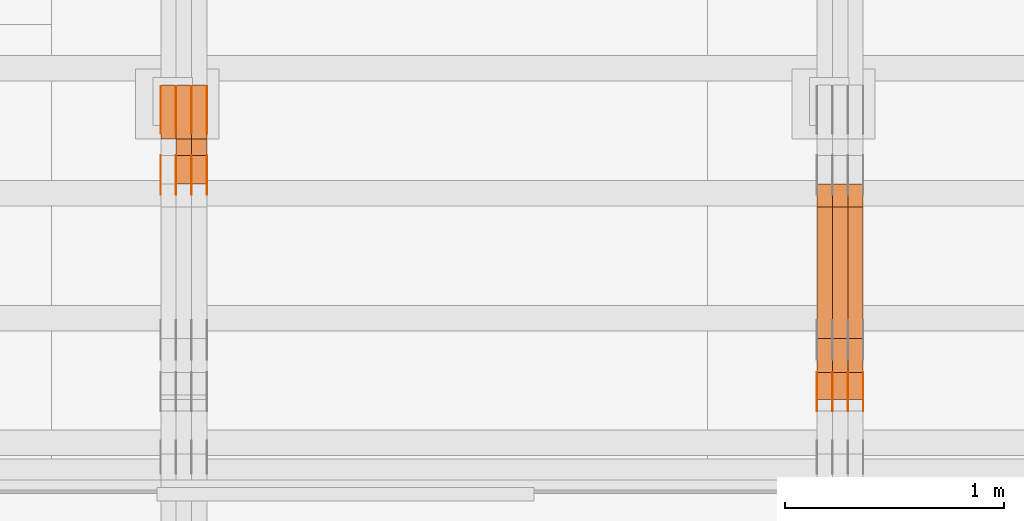
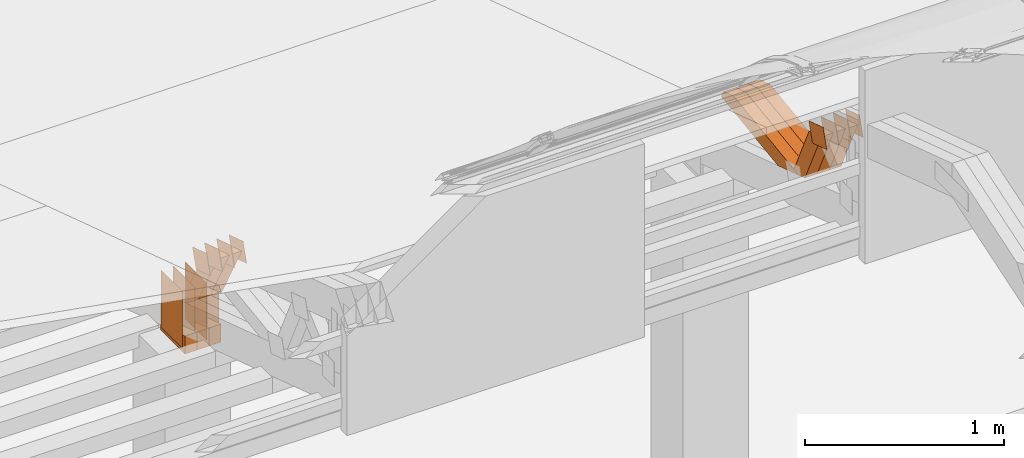
# One storey, part 163 of 385: 29 proxies.
"""IFC2X3 building model written with IfcOpenShell, lengths in millimetres."""

from ifc_helpers import new_model, entity, si_unit, converted_unit, derived_unit, direction, frame, origin, origin_2d_with_axis, place, context, subcontext, project, spatial, polyline, rectangle, outline, extrude, source, transform, mapped, material, type_object, type_shapes, element, save


model = new_model("IFC2X3")

# Units and contexts
model_context = context("Model", 3, precision=0.01, world=origin(), true_north=direction((6.12303176911189e-17, 1.0)))
body_context = subcontext(model_context, "Body", "Model", "MODEL_VIEW")
ifc_project = project(units=[si_unit("LENGTHUNIT", "METRE", prefix="MILLI"), si_unit("AREAUNIT", "SQUARE_METRE"), si_unit("VOLUMEUNIT", "CUBIC_METRE"), converted_unit("PLANEANGLEUNIT", "DEGREE", entity("IfcRatioMeasure", 0.0174532925199433), si_unit("PLANEANGLEUNIT", "RADIAN"), dimensions=[0, 0, 0, 0, 0, 0, 0]), si_unit("MASSUNIT", "GRAM", prefix="KILO"), derived_unit("MASSDENSITYUNIT", [(si_unit("MASSUNIT", "GRAM", prefix="KILO"), 1), (si_unit("LENGTHUNIT", "METRE"), -3)]), si_unit("TIMEUNIT", "SECOND"), si_unit("FREQUENCYUNIT", "HERTZ"), si_unit("THERMODYNAMICTEMPERATUREUNIT", "DEGREE_CELSIUS"), derived_unit("THERMALTRANSMITTANCEUNIT", [(si_unit("MASSUNIT", "GRAM", prefix="KILO"), 1), (si_unit("THERMODYNAMICTEMPERATUREUNIT", "KELVIN"), -1), (si_unit("TIMEUNIT", "SECOND"), -3)]), derived_unit("VOLUMETRICFLOWRATEUNIT", [(si_unit("LENGTHUNIT", "METRE"), 3), (si_unit("TIMEUNIT", "SECOND"), -1)]), si_unit("ELECTRICCURRENTUNIT", "AMPERE"), si_unit("ELECTRICVOLTAGEUNIT", "VOLT"), si_unit("POWERUNIT", "WATT"), si_unit("FORCEUNIT", "NEWTON", prefix="KILO"), si_unit("ILLUMINANCEUNIT", "LUX"), si_unit("LUMINOUSFLUXUNIT", "LUMEN"), si_unit("LUMINOUSINTENSITYUNIT", "CANDELA"), derived_unit("USERDEFINED", [(si_unit("MASSUNIT", "GRAM", prefix="KILO"), -1), (si_unit("LENGTHUNIT", "METRE"), -2), (si_unit("TIMEUNIT", "SECOND"), 3), (si_unit("LUMINOUSFLUXUNIT", "LUMEN"), 1)]), derived_unit("LINEARVELOCITYUNIT", [(si_unit("LENGTHUNIT", "METRE"), 1), (si_unit("TIMEUNIT", "SECOND"), -1)]), si_unit("PRESSUREUNIT", "PASCAL"), derived_unit("USERDEFINED", [(si_unit("LENGTHUNIT", "METRE"), -2), (si_unit("MASSUNIT", "GRAM", prefix="KILO"), 1), (si_unit("TIMEUNIT", "SECOND"), -2)])], contexts=[model_context])

# Site, building, storey
site_placement = place(None, origin())
site = spatial("IfcSite", under=ifc_project, at=site_placement, CompositionType="ELEMENT")
building_placement = place(site_placement, origin())
building = spatial("IfcBuilding", under=site, at=building_placement, CompositionType="ELEMENT")
storey_placement = place(building_placement, origin())
storey = spatial("IfcBuildingStorey", under=building, at=storey_placement, Name="Default", CompositionType="ELEMENT", Elevation=0.0)

# Proxies
ifc_material_1 = material(Name="IfcSurfaceStyle #338318")
building_element_proxy_type_1 = type_object("IfcBuildingElementProxyType", PredefinedType="NOTDEFINED", material=ifc_material_1)
shared_shape_1 = source(origin(), body_context, "Body", "SweptSolid", [
    extrude(outline(polyline([(-75.0003249421702, -60.0000773549573), (75.0003398116874, -60.0000773549573), (75.0003249421711, 60.0000773549573), (-75.0003398116883, 60.0000773549573), (-75.0003249421702, -60.0000773549573)])), frame((75.0003398116874, 60.0000773549573, 0.0), z_axis=(0.0, 0.0, 1.0), x_axis=(-1.0, 0.0, 0.0)), (0.0, 0.0, 1.0), 1.3),
])
type_shapes(building_element_proxy_type_1, [shared_shape_1])
proxy_1_placement = place(building_placement, frame((27386.3, 16117.0849050545, 3705.49074668796), z_axis=(-1.0, 0.0, 0.0), x_axis=(0.0, -0.951056516295154, 0.309016994374948)))
element("IfcBuildingElementProxy", 1, at=proxy_1_placement, inside=storey, type_object=building_element_proxy_type_1, material=ifc_material_1, context=body_context, shape_type="MappedRepresentation", body=[
    mapped(shared_shape_1, transform((0.0, 0.0, 0.0), scale=1.0)),
])
ifc_material_2 = material(Name="IfcSurfaceStyle #338261")
building_element_proxy_type_2 = type_object("IfcBuildingElementProxyType", PredefinedType="NOTDEFINED", material=ifc_material_2)
shared_shape_2 = source(origin(), body_context, "Body", "SweptSolid", [
    extrude(outline(polyline([(-75.0003249421702, -60.0000773549573), (75.0003398116874, -60.0000773549573), (75.0003249421711, 60.0000773549573), (-75.0003398116883, 60.0000773549573), (-75.0003249421702, -60.0000773549573)])), frame((75.0003398116874, 60.0000773549573, 0.0), z_axis=(0.0, 0.0, 1.0), x_axis=(-1.0, 0.0, 0.0)), (0.0, 0.0, 1.0), 1.3),
])
type_shapes(building_element_proxy_type_2, [shared_shape_2])
proxy_2_placement = place(building_placement, frame((27315.0, 16117.0849050545, 3705.49074668796), z_axis=(-1.0, 0.0, 0.0), x_axis=(0.0, -0.951056516295154, 0.309016994374948)))
element("IfcBuildingElementProxy", 2, at=proxy_2_placement, inside=storey, type_object=building_element_proxy_type_2, material=ifc_material_2, context=body_context, shape_type="MappedRepresentation", body=[
    mapped(shared_shape_2, transform((0.0, 0.0, 0.0), scale=1.0)),
])
ifc_material_3 = material(Name="IfcSurfaceStyle #338204")
building_element_proxy_type_3 = type_object("IfcBuildingElementProxyType", PredefinedType="NOTDEFINED", material=ifc_material_3)
shared_shape_3 = source(origin(), body_context, "Body", "SweptSolid", [
    extrude(outline(polyline([(-75.0003249421702, -60.0000773549573), (75.0003398116874, -60.0000773549573), (75.0003249421711, 60.0000773549573), (-75.0003398116883, 60.0000773549573), (-75.0003249421702, -60.0000773549573)])), frame((75.0003398116874, 60.0000773549573, 0.0), z_axis=(0.0, 0.0, 1.0), x_axis=(-1.0, 0.0, 0.0)), (0.0, 0.0, 1.0), 1.3),
])
type_shapes(building_element_proxy_type_3, [shared_shape_3])
proxy_3_placement = place(building_placement, frame((27316.3, 16117.0849050545, 3705.49074668796), z_axis=(-1.0, 0.0, 0.0), x_axis=(0.0, -0.951056516295154, 0.309016994374948)))
element("IfcBuildingElementProxy", 3, at=proxy_3_placement, inside=storey, type_object=building_element_proxy_type_3, material=ifc_material_3, context=body_context, shape_type="MappedRepresentation", body=[
    mapped(shared_shape_3, transform((0.0, 0.0, 0.0), scale=1.0)),
])
ifc_material_4 = material(Name="IfcSurfaceStyle #338147")
building_element_proxy_type_4 = type_object("IfcBuildingElementProxyType", PredefinedType="NOTDEFINED", material=ifc_material_4)
shared_shape_4 = source(origin(), body_context, "Body", "SweptSolid", [
    extrude(outline(polyline([(-75.0003249421702, -60.0000773549573), (75.0003398116874, -60.0000773549573), (75.0003249421711, 60.0000773549573), (-75.0003398116883, 60.0000773549573), (-75.0003249421702, -60.0000773549573)])), frame((75.0003398116874, 60.0000773549573, 0.0), z_axis=(0.0, 0.0, 1.0), x_axis=(-1.0, 0.0, 0.0)), (0.0, 0.0, 1.0), 1.29999999999999),
])
type_shapes(building_element_proxy_type_4, [shared_shape_4])
proxy_4_placement = place(building_placement, frame((27245.0, 16117.0849050545, 3705.49074668796), z_axis=(-1.0, 0.0, 0.0), x_axis=(0.0, -0.951056516295154, 0.309016994374948)))
element("IfcBuildingElementProxy", 4, at=proxy_4_placement, inside=storey, type_object=building_element_proxy_type_4, material=ifc_material_4, context=body_context, shape_type="MappedRepresentation", body=[
    mapped(shared_shape_4, transform((0.0, 0.0, 0.0), scale=1.0)),
])
ifc_material_5 = material(Name="IfcSurfaceStyle #338090")
building_element_proxy_type_5 = type_object("IfcBuildingElementProxyType", PredefinedType="NOTDEFINED", material=ifc_material_5)
shared_shape_5 = source(origin(), body_context, "Body", "SweptSolid", [
    extrude(outline(polyline([(-75.0003249421702, -60.0000773549573), (75.0003398116874, -60.0000773549573), (75.0003249421711, 60.0000773549573), (-75.0003398116883, 60.0000773549573), (-75.0003249421702, -60.0000773549573)])), frame((75.0003398116874, 60.0000773549573, 0.0), z_axis=(0.0, 0.0, 1.0), x_axis=(-1.0, 0.0, 0.0)), (0.0, 0.0, 1.0), 1.29999999999999),
])
type_shapes(building_element_proxy_type_5, [shared_shape_5])
proxy_5_placement = place(building_placement, frame((27246.3, 16117.0849050545, 3705.49074668796), z_axis=(-1.0, 0.0, 0.0), x_axis=(0.0, -0.951056516295154, 0.309016994374948)))
element("IfcBuildingElementProxy", 5, at=proxy_5_placement, inside=storey, type_object=building_element_proxy_type_5, material=ifc_material_5, context=body_context, shape_type="MappedRepresentation", body=[
    mapped(shared_shape_5, transform((0.0, 0.0, 0.0), scale=1.0)),
])
ifc_material_6 = material(Name="IfcSurfaceStyle #338033")
building_element_proxy_type_6 = type_object("IfcBuildingElementProxyType", PredefinedType="NOTDEFINED", material=ifc_material_6)
shared_shape_6 = source(origin(), body_context, "Body", "SweptSolid", [
    extrude(outline(polyline([(-75.0003249421702, -60.0000773549573), (75.0003398116874, -60.0000773549573), (75.0003249421711, 60.0000773549573), (-75.0003398116883, 60.0000773549573), (-75.0003249421702, -60.0000773549573)])), frame((75.0003398116874, 60.0000773549573, 0.0), z_axis=(0.0, 0.0, 1.0), x_axis=(-1.0, 0.0, 0.0)), (0.0, 0.0, 1.0), 1.29999999999999),
])
type_shapes(building_element_proxy_type_6, [shared_shape_6])
proxy_6_placement = place(building_placement, frame((27175.0, 16117.0849050545, 3705.49074668796), z_axis=(-1.0, 0.0, 0.0), x_axis=(0.0, -0.951056516295154, 0.309016994374948)))
element("IfcBuildingElementProxy", 6, at=proxy_6_placement, inside=storey, type_object=building_element_proxy_type_6, material=ifc_material_6, context=body_context, shape_type="MappedRepresentation", body=[
    mapped(shared_shape_6, transform((0.0, 0.0, 0.0), scale=1.0)),
])
ifc_material_7 = material(Name="IfcSurfaceStyle #327698")
building_element_proxy_type_7 = type_object("IfcBuildingElementProxyType", Name="T1-W44 327696", PredefinedType="NOTDEFINED", material=ifc_material_7)
shared_shape_7 = source(origin(), body_context, "Body", "SweptSolid", [
    extrude(outline(polyline([(-184.551057772692, -47.4997984945814), (177.527112951531, -47.4997984945814), (162.630077773546, -0.000452497529500495), (118.068221667048, 47.5000247433462), (-273.674354619433, 47.5000247433462), (-184.551057772692, -47.4997984945814)])), frame((177.527112951531, 47.5002721629815, 0.0), z_axis=(0.0, 0.0, 1.0), x_axis=(-1.0, 0.0, 0.0)), (0.0, 0.0, 1.0), 70.0),
])
type_shapes(building_element_proxy_type_7, [shared_shape_7])
proxy_7_placement = place(building_placement, frame((27385.0, 16220.4899216004, 3388.98238154171), z_axis=(-1.0, 0.0, 0.0), x_axis=(0.0, -0.425335045192995, 0.905035965766374)))
element("IfcBuildingElementProxy", 7, at=proxy_7_placement, inside=storey, type_object=building_element_proxy_type_7, material=ifc_material_7, Name="T1-W44", context=body_context, shape_type="MappedRepresentation", body=[
    mapped(shared_shape_7, transform((0.0, 0.0, 0.0), scale=1.0)),
])
ifc_material_8 = material(Name="IfcSurfaceStyle #327632")
building_element_proxy_type_8 = type_object("IfcBuildingElementProxyType", Name="T1-W44 327630", PredefinedType="NOTDEFINED", material=ifc_material_8)
shared_shape_8 = source(origin(), body_context, "Body", "SweptSolid", [
    extrude(outline(polyline([(-184.551057772692, -47.4997984945814), (177.527112951531, -47.4997984945814), (162.630077773546, -0.000452497529500495), (118.068221667048, 47.5000247433462), (-273.674354619433, 47.5000247433462), (-184.551057772692, -47.4997984945814)])), frame((177.527112951531, 47.5002721629815, 0.0), z_axis=(0.0, 0.0, 1.0), x_axis=(-1.0, 0.0, 0.0)), (0.0, 0.0, 1.0), 70.0),
])
type_shapes(building_element_proxy_type_8, [shared_shape_8])
proxy_8_placement = place(building_placement, frame((27315.0, 16220.4899216004, 3388.98238154171), z_axis=(-1.0, 0.0, 0.0), x_axis=(0.0, -0.425335045192995, 0.905035965766374)))
element("IfcBuildingElementProxy", 8, at=proxy_8_placement, inside=storey, type_object=building_element_proxy_type_8, material=ifc_material_8, Name="T1-W44", context=body_context, shape_type="MappedRepresentation", body=[
    mapped(shared_shape_8, transform((0.0, 0.0, 0.0), scale=1.0)),
])
ifc_material_9 = material(Name="IfcSurfaceStyle #327566")
building_element_proxy_type_9 = type_object("IfcBuildingElementProxyType", Name="T1-W44 327564", PredefinedType="NOTDEFINED", material=ifc_material_9)
shared_shape_9 = source(origin(), body_context, "Body", "SweptSolid", [
    extrude(outline(polyline([(-184.551057772692, -47.4997984945814), (177.527112951531, -47.4997984945814), (162.630077773546, -0.000452497529500495), (118.068221667048, 47.5000247433462), (-273.674354619433, 47.5000247433462), (-184.551057772692, -47.4997984945814)])), frame((177.527112951531, 47.5002721629815, 0.0), z_axis=(0.0, 0.0, 1.0), x_axis=(-1.0, 0.0, 0.0)), (0.0, 0.0, 1.0), 70.0),
])
type_shapes(building_element_proxy_type_9, [shared_shape_9])
proxy_9_placement = place(building_placement, frame((27245.0, 16220.4899216004, 3388.98238154171), z_axis=(-1.0, 0.0, 0.0), x_axis=(0.0, -0.425335045192995, 0.905035965766374)))
element("IfcBuildingElementProxy", 9, at=proxy_9_placement, inside=storey, type_object=building_element_proxy_type_9, material=ifc_material_9, Name="T1-W44", context=body_context, shape_type="MappedRepresentation", body=[
    mapped(shared_shape_9, transform((0.0, 0.0, 0.0), scale=1.0)),
])
ifc_material_10 = material(Name="IfcSurfaceStyle #327302")
building_element_proxy_type_10 = type_object("IfcBuildingElementProxyType", Name="T1-W8 327300", PredefinedType="NOTDEFINED", material=ifc_material_10)
shared_shape_10 = source(origin(), body_context, "Body", "SweptSolid", [
    extrude(outline(polyline([(-476.725263324644, -47.5001051695965), (180.672765845439, -47.5001051695965), (279.11020091716, -1.03605560390907e-06), (296.793624402619, 47.5001056876243), (-279.851327840575, 47.5001056876243), (-476.725263324644, -47.5001051695965)])), frame((296.793624402619, 47.5001056876243, 0.0), z_axis=(0.0, 0.0, 1.0), x_axis=(-1.0, 0.0, 0.0)), (0.0, 0.0, 1.0), 70.0),
])
type_shapes(building_element_proxy_type_10, [shared_shape_10])
proxy_10_placement = place(building_placement, frame((27385.0, 17036.40625, 3432.97192382813), z_axis=(-1.0, 0.0, 0.0), x_axis=(0.0, -0.990844046556832, -0.135011389900564)))
element("IfcBuildingElementProxy", 10, at=proxy_10_placement, inside=storey, type_object=building_element_proxy_type_10, material=ifc_material_10, Name="T1-W8", context=body_context, shape_type="MappedRepresentation", body=[
    mapped(shared_shape_10, transform((0.0, 0.0, 0.0), scale=1.0)),
])
ifc_material_11 = material(Name="IfcSurfaceStyle #327236")
building_element_proxy_type_11 = type_object("IfcBuildingElementProxyType", Name="T1-W8 327234", PredefinedType="NOTDEFINED", material=ifc_material_11)
shared_shape_11 = source(origin(), body_context, "Body", "SweptSolid", [
    extrude(outline(polyline([(-476.725263324644, -47.5001051695965), (180.672765845439, -47.5001051695965), (279.11020091716, -1.03605560390907e-06), (296.793624402619, 47.5001056876243), (-279.851327840575, 47.5001056876243), (-476.725263324644, -47.5001051695965)])), frame((296.793624402619, 47.5001056876243, 0.0), z_axis=(0.0, 0.0, 1.0), x_axis=(-1.0, 0.0, 0.0)), (0.0, 0.0, 1.0), 70.0),
])
type_shapes(building_element_proxy_type_11, [shared_shape_11])
proxy_11_placement = place(building_placement, frame((27315.0, 17036.40625, 3432.97192382813), z_axis=(-1.0, 0.0, 0.0), x_axis=(0.0, -0.990844046556832, -0.135011389900564)))
element("IfcBuildingElementProxy", 11, at=proxy_11_placement, inside=storey, type_object=building_element_proxy_type_11, material=ifc_material_11, Name="T1-W8", context=body_context, shape_type="MappedRepresentation", body=[
    mapped(shared_shape_11, transform((0.0, 0.0, 0.0), scale=1.0)),
])
ifc_material_12 = material(Name="IfcSurfaceStyle #327170")
building_element_proxy_type_12 = type_object("IfcBuildingElementProxyType", Name="T1-W8 327168", PredefinedType="NOTDEFINED", material=ifc_material_12)
shared_shape_12 = source(origin(), body_context, "Body", "SweptSolid", [
    extrude(outline(polyline([(-476.725263324644, -47.5001051695965), (180.672765845439, -47.5001051695965), (279.11020091716, -1.03605560390907e-06), (296.793624402619, 47.5001056876243), (-279.851327840575, 47.5001056876243), (-476.725263324644, -47.5001051695965)])), frame((296.793624402619, 47.5001056876243, 0.0), z_axis=(0.0, 0.0, 1.0), x_axis=(-1.0, 0.0, 0.0)), (0.0, 0.0, 1.0), 70.0),
])
type_shapes(building_element_proxy_type_12, [shared_shape_12])
proxy_12_placement = place(building_placement, frame((27245.0, 17036.40625, 3432.97192382813), z_axis=(-1.0, 0.0, 0.0), x_axis=(0.0, -0.990844046556832, -0.135011389900564)))
element("IfcBuildingElementProxy", 12, at=proxy_12_placement, inside=storey, type_object=building_element_proxy_type_12, material=ifc_material_12, Name="T1-W8", context=body_context, shape_type="MappedRepresentation", body=[
    mapped(shared_shape_12, transform((0.0, 0.0, 0.0), scale=1.0)),
])
ifc_material_13 = material(Name="IfcSurfaceStyle #305938")
building_element_proxy_type_13 = type_object("IfcBuildingElementProxyType", PredefinedType="NOTDEFINED", material=ifc_material_13)
shared_shape_13 = source(origin(), body_context, "Body", "SweptSolid", [
    extrude(rectangle(XDim=350.0, YDim=215.999999999984, at=origin_2d_with_axis()), frame((175.0, 108.0, 0.0), z_axis=(0.0, 0.0, 1.0), x_axis=(-1.0, 0.0, 0.0)), (0.0, 0.0, 1.0), 1.29999999999999),
])
type_shapes(building_element_proxy_type_13, [shared_shape_13])
proxy_13_placement = place(building_placement, frame((24386.3, 17459.2939453125, 3165.36425781251), z_axis=(-1.0, 0.0, 0.0), x_axis=(0.0, 0.0, -1.0)))
element("IfcBuildingElementProxy", 13, at=proxy_13_placement, inside=storey, type_object=building_element_proxy_type_13, material=ifc_material_13, context=body_context, shape_type="MappedRepresentation", body=[
    mapped(shared_shape_13, transform((0.0, 0.0, 0.0), scale=1.0)),
])
ifc_material_14 = material(Name="IfcSurfaceStyle #305881")
building_element_proxy_type_14 = type_object("IfcBuildingElementProxyType", PredefinedType="NOTDEFINED", material=ifc_material_14)
shared_shape_14 = source(origin(), body_context, "Body", "SweptSolid", [
    extrude(rectangle(XDim=350.0, YDim=215.999999999984, at=origin_2d_with_axis()), frame((175.0, 108.0, 0.0), z_axis=(0.0, 0.0, 1.0), x_axis=(-1.0, 0.0, 0.0)), (0.0, 0.0, 1.0), 1.29999999999999),
])
type_shapes(building_element_proxy_type_14, [shared_shape_14])
proxy_14_placement = place(building_placement, frame((24315.0, 17459.2939453125, 3165.36425781251), z_axis=(-1.0, 0.0, 0.0), x_axis=(0.0, 0.0, -1.0)))
element("IfcBuildingElementProxy", 14, at=proxy_14_placement, inside=storey, type_object=building_element_proxy_type_14, material=ifc_material_14, context=body_context, shape_type="MappedRepresentation", body=[
    mapped(shared_shape_14, transform((0.0, 0.0, 0.0), scale=1.0)),
])
ifc_material_15 = material(Name="IfcSurfaceStyle #305824")
building_element_proxy_type_15 = type_object("IfcBuildingElementProxyType", PredefinedType="NOTDEFINED", material=ifc_material_15)
shared_shape_15 = source(origin(), body_context, "Body", "SweptSolid", [
    extrude(rectangle(XDim=350.0, YDim=215.999999999984, at=origin_2d_with_axis()), frame((175.0, 108.0, 0.0), z_axis=(0.0, 0.0, 1.0), x_axis=(-1.0, 0.0, 0.0)), (0.0, 0.0, 1.0), 1.29999999999999),
])
type_shapes(building_element_proxy_type_15, [shared_shape_15])
proxy_15_placement = place(building_placement, frame((24316.3, 17459.2939453125, 3165.36425781251), z_axis=(-1.0, 0.0, 0.0), x_axis=(0.0, 0.0, -1.0)))
element("IfcBuildingElementProxy", 15, at=proxy_15_placement, inside=storey, type_object=building_element_proxy_type_15, material=ifc_material_15, context=body_context, shape_type="MappedRepresentation", body=[
    mapped(shared_shape_15, transform((0.0, 0.0, 0.0), scale=1.0)),
])
ifc_material_16 = material(Name="IfcSurfaceStyle #305767")
building_element_proxy_type_16 = type_object("IfcBuildingElementProxyType", PredefinedType="NOTDEFINED", material=ifc_material_16)
shared_shape_16 = source(origin(), body_context, "Body", "SweptSolid", [
    extrude(rectangle(XDim=350.0, YDim=215.999999999984, at=origin_2d_with_axis()), frame((175.0, 108.0, 0.0), z_axis=(0.0, 0.0, 1.0), x_axis=(-1.0, 0.0, 0.0)), (0.0, 0.0, 1.0), 1.29999999999998),
])
type_shapes(building_element_proxy_type_16, [shared_shape_16])
proxy_16_placement = place(building_placement, frame((24245.0, 17459.2939453125, 3165.36425781251), z_axis=(-1.0, 0.0, 0.0), x_axis=(0.0, 0.0, -1.0)))
element("IfcBuildingElementProxy", 16, at=proxy_16_placement, inside=storey, type_object=building_element_proxy_type_16, material=ifc_material_16, context=body_context, shape_type="MappedRepresentation", body=[
    mapped(shared_shape_16, transform((0.0, 0.0, 0.0), scale=1.0)),
])
ifc_material_17 = material(Name="IfcSurfaceStyle #305710")
building_element_proxy_type_17 = type_object("IfcBuildingElementProxyType", PredefinedType="NOTDEFINED", material=ifc_material_17)
shared_shape_17 = source(origin(), body_context, "Body", "SweptSolid", [
    extrude(rectangle(XDim=350.0, YDim=215.999999999984, at=origin_2d_with_axis()), frame((175.0, 108.0, 0.0), z_axis=(0.0, 0.0, 1.0), x_axis=(-1.0, 0.0, 0.0)), (0.0, 0.0, 1.0), 1.29999999999998),
])
type_shapes(building_element_proxy_type_17, [shared_shape_17])
proxy_17_placement = place(building_placement, frame((24246.3, 17459.2939453125, 3165.36425781251), z_axis=(-1.0, 0.0, 0.0), x_axis=(0.0, 0.0, -1.0)))
element("IfcBuildingElementProxy", 17, at=proxy_17_placement, inside=storey, type_object=building_element_proxy_type_17, material=ifc_material_17, context=body_context, shape_type="MappedRepresentation", body=[
    mapped(shared_shape_17, transform((0.0, 0.0, 0.0), scale=1.0)),
])
ifc_material_18 = material(Name="IfcSurfaceStyle #305653")
building_element_proxy_type_18 = type_object("IfcBuildingElementProxyType", PredefinedType="NOTDEFINED", material=ifc_material_18)
shared_shape_18 = source(origin(), body_context, "Body", "SweptSolid", [
    extrude(rectangle(XDim=350.0, YDim=215.999999999984, at=origin_2d_with_axis()), frame((175.0, 108.0, 0.0), z_axis=(0.0, 0.0, 1.0), x_axis=(-1.0, 0.0, 0.0)), (0.0, 0.0, 1.0), 1.29999999999998),
])
type_shapes(building_element_proxy_type_18, [shared_shape_18])
proxy_18_placement = place(building_placement, frame((24175.0, 17459.2939453125, 3165.36425781251), z_axis=(-1.0, 0.0, 0.0), x_axis=(0.0, 0.0, -1.0)))
element("IfcBuildingElementProxy", 18, at=proxy_18_placement, inside=storey, type_object=building_element_proxy_type_18, material=ifc_material_18, context=body_context, shape_type="MappedRepresentation", body=[
    mapped(shared_shape_18, transform((0.0, 0.0, 0.0), scale=1.0)),
])
ifc_material_19 = material(Name="IfcSurfaceStyle #302518")
building_element_proxy_type_19 = type_object("IfcBuildingElementProxyType", PredefinedType="NOTDEFINED", material=ifc_material_19)
shared_shape_19 = source(origin(), body_context, "Body", "SweptSolid", [
    extrude(outline(polyline([(-74.9998605591058, -59.9999264677524), (74.999875428623, -59.9999264677524), (74.9998605591068, 59.9999264677524), (-74.9998754286239, 59.9999264677524), (-74.9998605591058, -59.9999264677524)])), frame((75.0002460484325, 60.0000016373508, 0.0), z_axis=(0.0, 0.0, 1.0), x_axis=(-1.0, 0.0, 0.0)), (0.0, 0.0, 1.0), 1.3),
])
type_shapes(building_element_proxy_type_19, [shared_shape_19])
proxy_19_placement = place(building_placement, frame((24386.3, 17107.0599369346, 3383.82825001787), z_axis=(-1.0, 0.0, 0.0), x_axis=(0.0, -0.951056516295154, 0.309016994374948)))
element("IfcBuildingElementProxy", 19, at=proxy_19_placement, inside=storey, type_object=building_element_proxy_type_19, material=ifc_material_19, context=body_context, shape_type="MappedRepresentation", body=[
    mapped(shared_shape_19, transform((0.0, 0.0, 0.0), scale=1.0)),
])
ifc_material_20 = material(Name="IfcSurfaceStyle #302461")
building_element_proxy_type_20 = type_object("IfcBuildingElementProxyType", PredefinedType="NOTDEFINED", material=ifc_material_20)
shared_shape_20 = source(origin(), body_context, "Body", "SweptSolid", [
    extrude(outline(polyline([(-74.9998605591058, -59.9999264677524), (74.999875428623, -59.9999264677524), (74.9998605591068, 59.9999264677524), (-74.9998754286239, 59.9999264677524), (-74.9998605591058, -59.9999264677524)])), frame((75.0002460484325, 60.0000016373508, 0.0), z_axis=(0.0, 0.0, 1.0), x_axis=(-1.0, 0.0, 0.0)), (0.0, 0.0, 1.0), 1.3),
])
type_shapes(building_element_proxy_type_20, [shared_shape_20])
proxy_20_placement = place(building_placement, frame((24315.0, 17107.0599369346, 3383.82825001787), z_axis=(-1.0, 0.0, 0.0), x_axis=(0.0, -0.951056516295154, 0.309016994374948)))
element("IfcBuildingElementProxy", 20, at=proxy_20_placement, inside=storey, type_object=building_element_proxy_type_20, material=ifc_material_20, context=body_context, shape_type="MappedRepresentation", body=[
    mapped(shared_shape_20, transform((0.0, 0.0, 0.0), scale=1.0)),
])
ifc_material_21 = material(Name="IfcSurfaceStyle #302404")
building_element_proxy_type_21 = type_object("IfcBuildingElementProxyType", PredefinedType="NOTDEFINED", material=ifc_material_21)
shared_shape_21 = source(origin(), body_context, "Body", "SweptSolid", [
    extrude(outline(polyline([(-74.9998605591058, -59.9999264677524), (74.999875428623, -59.9999264677524), (74.9998605591068, 59.9999264677524), (-74.9998754286239, 59.9999264677524), (-74.9998605591058, -59.9999264677524)])), frame((75.0002460484325, 60.0000016373508, 0.0), z_axis=(0.0, 0.0, 1.0), x_axis=(-1.0, 0.0, 0.0)), (0.0, 0.0, 1.0), 1.3),
])
type_shapes(building_element_proxy_type_21, [shared_shape_21])
proxy_21_placement = place(building_placement, frame((24316.3, 17107.0599369346, 3383.82825001787), z_axis=(-1.0, 0.0, 0.0), x_axis=(0.0, -0.951056516295154, 0.309016994374948)))
element("IfcBuildingElementProxy", 21, at=proxy_21_placement, inside=storey, type_object=building_element_proxy_type_21, material=ifc_material_21, context=body_context, shape_type="MappedRepresentation", body=[
    mapped(shared_shape_21, transform((0.0, 0.0, 0.0), scale=1.0)),
])
ifc_material_22 = material(Name="IfcSurfaceStyle #302347")
building_element_proxy_type_22 = type_object("IfcBuildingElementProxyType", PredefinedType="NOTDEFINED", material=ifc_material_22)
shared_shape_22 = source(origin(), body_context, "Body", "SweptSolid", [
    extrude(outline(polyline([(-74.9998605591058, -59.9999264677524), (74.999875428623, -59.9999264677524), (74.9998605591068, 59.9999264677524), (-74.9998754286239, 59.9999264677524), (-74.9998605591058, -59.9999264677524)])), frame((75.0002460484325, 60.0000016373508, 0.0), z_axis=(0.0, 0.0, 1.0), x_axis=(-1.0, 0.0, 0.0)), (0.0, 0.0, 1.0), 1.29999999999999),
])
type_shapes(building_element_proxy_type_22, [shared_shape_22])
proxy_22_placement = place(building_placement, frame((24245.0, 17107.0599369346, 3383.82825001787), z_axis=(-1.0, 0.0, 0.0), x_axis=(0.0, -0.951056516295154, 0.309016994374948)))
element("IfcBuildingElementProxy", 22, at=proxy_22_placement, inside=storey, type_object=building_element_proxy_type_22, material=ifc_material_22, context=body_context, shape_type="MappedRepresentation", body=[
    mapped(shared_shape_22, transform((0.0, 0.0, 0.0), scale=1.0)),
])
ifc_material_23 = material(Name="IfcSurfaceStyle #302290")
building_element_proxy_type_23 = type_object("IfcBuildingElementProxyType", PredefinedType="NOTDEFINED", material=ifc_material_23)
shared_shape_23 = source(origin(), body_context, "Body", "SweptSolid", [
    extrude(outline(polyline([(-74.9998605591058, -59.9999264677524), (74.999875428623, -59.9999264677524), (74.9998605591068, 59.9999264677524), (-74.9998754286239, 59.9999264677524), (-74.9998605591058, -59.9999264677524)])), frame((75.0002460484325, 60.0000016373508, 0.0), z_axis=(0.0, 0.0, 1.0), x_axis=(-1.0, 0.0, 0.0)), (0.0, 0.0, 1.0), 1.29999999999999),
])
type_shapes(building_element_proxy_type_23, [shared_shape_23])
proxy_23_placement = place(building_placement, frame((24246.3, 17107.0599369346, 3383.82825001787), z_axis=(-1.0, 0.0, 0.0), x_axis=(0.0, -0.951056516295154, 0.309016994374948)))
element("IfcBuildingElementProxy", 23, at=proxy_23_placement, inside=storey, type_object=building_element_proxy_type_23, material=ifc_material_23, context=body_context, shape_type="MappedRepresentation", body=[
    mapped(shared_shape_23, transform((0.0, 0.0, 0.0), scale=1.0)),
])
ifc_material_24 = material(Name="IfcSurfaceStyle #302233")
building_element_proxy_type_24 = type_object("IfcBuildingElementProxyType", PredefinedType="NOTDEFINED", material=ifc_material_24)
shared_shape_24 = source(origin(), body_context, "Body", "SweptSolid", [
    extrude(outline(polyline([(-74.9998605591058, -59.9999264677524), (74.999875428623, -59.9999264677524), (74.9998605591068, 59.9999264677524), (-74.9998754286239, 59.9999264677524), (-74.9998605591058, -59.9999264677524)])), frame((75.0002460484325, 60.0000016373508, 0.0), z_axis=(0.0, 0.0, 1.0), x_axis=(-1.0, 0.0, 0.0)), (0.0, 0.0, 1.0), 1.29999999999999),
])
type_shapes(building_element_proxy_type_24, [shared_shape_24])
proxy_24_placement = place(building_placement, frame((24175.0, 17107.0599369346, 3383.82825001787), z_axis=(-1.0, 0.0, 0.0), x_axis=(0.0, -0.951056516295154, 0.309016994374948)))
element("IfcBuildingElementProxy", 24, at=proxy_24_placement, inside=storey, type_object=building_element_proxy_type_24, material=ifc_material_24, context=body_context, shape_type="MappedRepresentation", body=[
    mapped(shared_shape_24, transform((0.0, 0.0, 0.0), scale=1.0)),
])
ifc_material_25 = material(Name="IfcSurfaceStyle #294229")
building_element_proxy_type_25 = type_object("IfcBuildingElementProxyType", Name="T1-E1 294227", PredefinedType="NOTDEFINED", material=ifc_material_25)
shared_shape_25 = source(origin(), body_context, "Body", "SweptSolid", [
    extrude(outline(polyline([(4.4675903320374, -122.500000000001), (35.3350219726624, -122.500000000001), (35.3350219726501, 122.500000000001), (-75.1376342773499, 122.500000000001), (4.4675903320374, -122.500000000001)])), frame((35.3350219726624, 122.50000005215, 0.0), z_axis=(0.0, 0.0, 1.0), x_axis=(-1.0, 0.0, 0.0)), (0.0, 0.0, 1.0), 70.0),
])
type_shapes(building_element_proxy_type_25, [shared_shape_25])
proxy_25_placement = place(building_placement, frame((24385.0, 17220.0, 2794.30932617186), z_axis=(-1.0, 0.0, 0.0), x_axis=(0.0, 0.0, 1.0)))
element("IfcBuildingElementProxy", 25, at=proxy_25_placement, inside=storey, type_object=building_element_proxy_type_25, material=ifc_material_25, Name="T1-E1", context=body_context, shape_type="MappedRepresentation", body=[
    mapped(shared_shape_25, transform((0.0, 0.0, 0.0), scale=1.0)),
])
ifc_material_26 = material(Name="IfcSurfaceStyle #294172")
building_element_proxy_type_26 = type_object("IfcBuildingElementProxyType", Name="T1-E1 294170", PredefinedType="NOTDEFINED", material=ifc_material_26)
shared_shape_26 = source(origin(), body_context, "Body", "SweptSolid", [
    extrude(outline(polyline([(4.4675903320374, -122.500000000001), (35.3350219726624, -122.500000000001), (35.3350219726501, 122.500000000001), (-75.1376342773499, 122.500000000001), (4.4675903320374, -122.500000000001)])), frame((35.3350219726624, 122.50000005215, 0.0), z_axis=(0.0, 0.0, 1.0), x_axis=(-1.0, 0.0, 0.0)), (0.0, 0.0, 1.0), 70.0),
])
type_shapes(building_element_proxy_type_26, [shared_shape_26])
proxy_26_placement = place(building_placement, frame((24315.0, 17220.0, 2794.30932617186), z_axis=(-1.0, 0.0, 0.0), x_axis=(0.0, 0.0, 1.0)))
element("IfcBuildingElementProxy", 26, at=proxy_26_placement, inside=storey, type_object=building_element_proxy_type_26, material=ifc_material_26, Name="T1-E1", context=body_context, shape_type="MappedRepresentation", body=[
    mapped(shared_shape_26, transform((0.0, 0.0, 0.0), scale=1.0)),
])
ifc_material_27 = material(Name="IfcSurfaceStyle #294115")
building_element_proxy_type_27 = type_object("IfcBuildingElementProxyType", Name="T1-E1 294113", PredefinedType="NOTDEFINED", material=ifc_material_27)
shared_shape_27 = source(origin(), body_context, "Body", "SweptSolid", [
    extrude(outline(polyline([(4.4675903320374, -122.500000000001), (35.3350219726624, -122.500000000001), (35.3350219726501, 122.500000000001), (-75.1376342773499, 122.500000000001), (4.4675903320374, -122.500000000001)])), frame((35.3350219726624, 122.50000005215, 0.0), z_axis=(0.0, 0.0, 1.0), x_axis=(-1.0, 0.0, 0.0)), (0.0, 0.0, 1.0), 70.0),
])
type_shapes(building_element_proxy_type_27, [shared_shape_27])
proxy_27_placement = place(building_placement, frame((24245.0, 17220.0, 2794.30932617186), z_axis=(-1.0, 0.0, 0.0), x_axis=(0.0, 0.0, 1.0)))
element("IfcBuildingElementProxy", 27, at=proxy_27_placement, inside=storey, type_object=building_element_proxy_type_27, material=ifc_material_27, Name="T1-E1", context=body_context, shape_type="MappedRepresentation", body=[
    mapped(shared_shape_27, transform((0.0, 0.0, 0.0), scale=1.0)),
])
ifc_material_28 = material(Name="IfcSurfaceStyle #292474")
building_element_proxy_type_28 = type_object("IfcBuildingElementProxyType", Name="T1-W39 292472", PredefinedType="NOTDEFINED", material=ifc_material_28)
shared_shape_28 = source(origin(), body_context, "Body", "SweptSolid", [
    extrude(outline(polyline([(-191.519946663886, -47.499928106579), (188.32936223763, -47.499928106579), (171.597440144109, 0.000249483340993841), (122.102882529753, 47.4998033649085), (-290.509738247605, 47.4998033649085), (-191.519946663886, -47.499928106579)])), frame((188.329593252001, 47.499957247623, 0.0), z_axis=(0.0, 0.0, 1.0), x_axis=(-1.0, 0.0, 0.0)), (0.0, 0.0, 1.0), 70.0),
])
type_shapes(building_element_proxy_type_28, [shared_shape_28])
proxy_28_placement = place(building_placement, frame((24385.0, 17238.5876916597, 3055.56121424762), z_axis=(-1.0, 0.0, 0.0), x_axis=(0.0, -0.472216932390777, 0.881482370080902)))
element("IfcBuildingElementProxy", 28, at=proxy_28_placement, inside=storey, type_object=building_element_proxy_type_28, material=ifc_material_28, Name="T1-W39", context=body_context, shape_type="MappedRepresentation", body=[
    mapped(shared_shape_28, transform((0.0, 0.0, 0.0), scale=1.0)),
])
ifc_material_29 = material(Name="IfcSurfaceStyle #292408")
building_element_proxy_type_29 = type_object("IfcBuildingElementProxyType", Name="T1-W39 292406", PredefinedType="NOTDEFINED", material=ifc_material_29)
shared_shape_29 = source(origin(), body_context, "Body", "SweptSolid", [
    extrude(outline(polyline([(-191.519946663886, -47.499928106579), (188.32936223763, -47.499928106579), (171.597440144109, 0.000249483340993841), (122.102882529753, 47.4998033649085), (-290.509738247605, 47.4998033649085), (-191.519946663886, -47.499928106579)])), frame((188.329593252001, 47.499957247623, 0.0), z_axis=(0.0, 0.0, 1.0), x_axis=(-1.0, 0.0, 0.0)), (0.0, 0.0, 1.0), 70.0),
])
type_shapes(building_element_proxy_type_29, [shared_shape_29])
proxy_29_placement = place(building_placement, frame((24315.0, 17238.5876916597, 3055.56121424762), z_axis=(-1.0, 0.0, 0.0), x_axis=(0.0, -0.472216932390777, 0.881482370080902)))
element("IfcBuildingElementProxy", 29, at=proxy_29_placement, inside=storey, type_object=building_element_proxy_type_29, material=ifc_material_29, Name="T1-W39", context=body_context, shape_type="MappedRepresentation", body=[
    mapped(shared_shape_29, transform((0.0, 0.0, 0.0), scale=1.0)),
])

save(model, "model.ifc")
